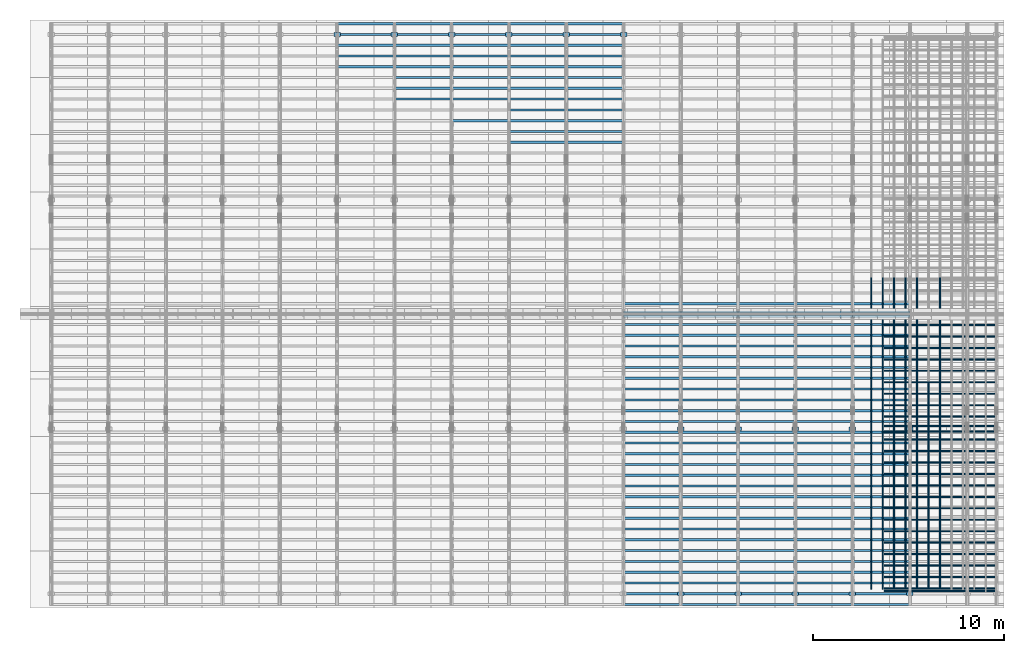
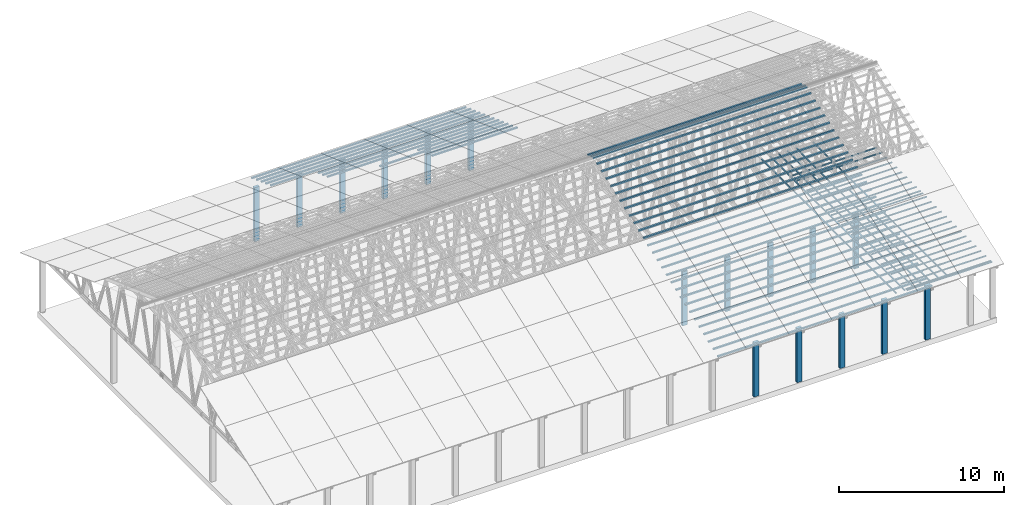
# One storey, part 3 of 189: 258 columns.
"""IFC2X3 building model written with IfcOpenShell, lengths in millimetres."""

from ifc_helpers import new_model, entity, si_unit, converted_unit, derived_unit, direction, frame, frame_2d, origin, origin_2d_with_axis, place, context, subcontext, project, spatial, rectangle, extrude, boolean, source, transform, mapped, material, type_object, type_shapes, element, save


model = new_model("IFC2X3")

# Units and contexts
model_context = context("Model", 3, precision=0.01, world=origin(), true_north=direction((6.12303176911189e-17, 1.0)))
body_context = subcontext(model_context, "Body", "Model", "MODEL_VIEW")
ifc_project = project(units=[si_unit("LENGTHUNIT", "METRE", prefix="MILLI"), si_unit("AREAUNIT", "SQUARE_METRE"), si_unit("VOLUMEUNIT", "CUBIC_METRE"), converted_unit("PLANEANGLEUNIT", "DEGREE", entity("IfcRatioMeasure", 0.0174532925199433), si_unit("PLANEANGLEUNIT", "RADIAN"), dimensions=[0, 0, 0, 0, 0, 0, 0]), si_unit("MASSUNIT", "GRAM", prefix="KILO"), derived_unit("MASSDENSITYUNIT", [(si_unit("MASSUNIT", "GRAM", prefix="KILO"), 1), (si_unit("LENGTHUNIT", "METRE"), -3)]), si_unit("TIMEUNIT", "SECOND"), si_unit("FREQUENCYUNIT", "HERTZ"), si_unit("THERMODYNAMICTEMPERATUREUNIT", "DEGREE_CELSIUS"), derived_unit("THERMALTRANSMITTANCEUNIT", [(si_unit("MASSUNIT", "GRAM", prefix="KILO"), 1), (si_unit("THERMODYNAMICTEMPERATUREUNIT", "KELVIN"), -1), (si_unit("TIMEUNIT", "SECOND"), -3)]), derived_unit("VOLUMETRICFLOWRATEUNIT", [(si_unit("LENGTHUNIT", "METRE"), 3), (si_unit("TIMEUNIT", "SECOND"), -1)]), si_unit("ELECTRICCURRENTUNIT", "AMPERE"), si_unit("ELECTRICVOLTAGEUNIT", "VOLT"), si_unit("POWERUNIT", "WATT"), si_unit("FORCEUNIT", "NEWTON"), si_unit("ILLUMINANCEUNIT", "LUX"), si_unit("LUMINOUSFLUXUNIT", "LUMEN"), si_unit("LUMINOUSINTENSITYUNIT", "CANDELA"), derived_unit("USERDEFINED", [(si_unit("MASSUNIT", "GRAM", prefix="KILO"), -1), (si_unit("LENGTHUNIT", "METRE"), -2), (si_unit("TIMEUNIT", "SECOND"), 3), (si_unit("LUMINOUSFLUXUNIT", "LUMEN"), 1)]), derived_unit("LINEARVELOCITYUNIT", [(si_unit("LENGTHUNIT", "METRE"), 1), (si_unit("TIMEUNIT", "SECOND"), -1)]), si_unit("PRESSUREUNIT", "PASCAL"), derived_unit("USERDEFINED", [(si_unit("LENGTHUNIT", "METRE"), -2), (si_unit("MASSUNIT", "GRAM", prefix="KILO"), 1), (si_unit("TIMEUNIT", "SECOND"), -2)])], contexts=[model_context])

# Site, building, storey
site_placement = place(None, origin())
site = spatial("IfcSite", under=ifc_project, at=site_placement, CompositionType="ELEMENT")
building_placement = place(site_placement, origin())
building = spatial("IfcBuilding", under=site, at=building_placement, CompositionType="ELEMENT")
storey_placement = place(building_placement, origin())
storey = spatial("IfcBuildingStorey", under=building, at=storey_placement, Name="Default", CompositionType="ELEMENT", Elevation=0.0)

# Columns
ifc_material_1 = material(Name="2")
column_type_1 = type_object("IfcColumnType", Name="100x70", PredefinedType="COLUMN")
shared_shape_1 = source(origin(), body_context, "Body", "CSG", [
    boolean("DIFFERENCE", extrude(rectangle(XDim=2998.26294985256, YDim=117.910672112436, at=frame_2d((0.0, -7.105427357601e-15), x_axis=(1.0, 0.0))), frame((1499.13147492628, 146.833369190677, -28.6286403914047)), (0.0, 0.0, 1.0), 99.9804977897746), extrude(rectangle(XDim=70.0000000018648, YDim=100.00000000027, at=frame_2d((3.5527136788005e-15, 3.5527136788005e-15), x_axis=(0.0, 1.0))), frame((2998.26294985256, 146.833369190677, 21.3616085034827), z_axis=(1.0, 0.0, 0.0), x_axis=(0.0, 0.939692620784201, -0.34202014333036)), (0.0, 0.0, -1.0), 2998.26294985256)),
])
type_shapes(column_type_1, [shared_shape_1])
for number, where, name in (
    (1, (42230.0, 15149.3712807029, 5585.64342365955), "H_28_35_gradi:100x70"),
    (2, (42230.0, 14712.1220107287, 5744.78914288479), "H_28_35_gradi:100x70"),
    (3, (39231.7370501475, 15149.3712807029, 5585.64342365955), "H_28_35_gradi:100x70"),
    (4, (39231.7370501475, 14712.1220107287, 5744.78914288479), "H_28_35_gradi:100x70"),
    (5, (36233.4741002949, 15149.3712807029, 5585.64342365955), "H_28_35_gradi:100x70"),
    (6, (36233.4741002949, 14712.1220107287, 5744.78914288479), "H_28_35_gradi:100x70"),
    (7, (33235.2111504423, 15149.3712807029, 5585.64342365955), "H_28_35_gradi:100x70"),
    (8, (33235.2111504423, 14712.1220107287, 5744.78914288479), "H_28_35_gradi:100x70"),
    (9, (30236.9482005898, 15149.3712807029, 5585.64342365955), "H_28_35_gradi:100x70"),
    (10, (30236.9482005898, 14712.1220107287, 5744.78914288479), "H_28_35_gradi:100x70"),
    (11, (27231.7370501475, 29808.5761649638, 250.129187781087), "H_28_35_gradi:100x70"),
    (12, (27231.7370501475, 29244.7605924922, 455.341273776488), "H_28_35_gradi:100x70"),
    (13, (27231.7370501475, 28680.94502002, 660.553359769929), "H_28_35_gradi:100x70"),
    (14, (27231.7370501475, 28117.1294475484, 865.765445765329), "H_28_35_gradi:100x70"),
    (15, (27231.7370501475, 27553.3138750769, 1070.97753176073), "H_28_35_gradi:100x70"),
    (16, (27231.7370501475, 26989.4983026054, 1276.18961775613), "H_28_35_gradi:100x70"),
    (17, (27231.7370501475, 26425.6827301338, 1481.40170375153), "H_28_35_gradi:100x70"),
    (18, (27231.7370501475, 25861.8671576623, 1686.61378974693), "H_28_35_gradi:100x70"),
    (19, (27231.7370501475, 25298.0515851907, 1891.82587574233), "H_28_35_gradi:100x70"),
    (20, (27231.7370501475, 24734.2360127192, 2097.03796173773), "H_28_35_gradi:100x70"),
    (21, (27231.7370501475, 24170.4204402476, 2302.25004773314), "H_28_35_gradi:100x70"),
    (22, (27231.7370501475, 23606.6048677761, 2507.46213372854), "H_28_35_gradi:100x70"),
    (23, (24233.4741002949, 29808.5761649638, 250.129187781087), "H_28_35_gradi:100x70"),
    (24, (24233.4741002949, 29244.7605924923, 455.341273776488), "H_28_35_gradi:100x70"),
    (25, (24233.4741002949, 28680.94502002, 660.553359769929), "H_28_35_gradi:100x70"),
    (26, (24233.4741002949, 28117.1294475485, 865.765445765329), "H_28_35_gradi:100x70"),
    (27, (24233.4741002949, 27553.3138750769, 1070.97753176073), "H_28_35_gradi:100x70"),
    (28, (24233.4741002949, 26989.4983026054, 1276.18961775613), "H_28_35_gradi:100x70"),
    (29, (24233.4741002949, 26425.6827301338, 1481.40170375153), "H_28_35_gradi:100x70"),
    (30, (24233.4741002949, 25861.8671576623, 1686.61378974693), "H_28_35_gradi:100x70"),
    (31, (24233.4741002949, 25298.0515851907, 1891.82587574233), "H_28_35_gradi:100x70"),
    (32, (24233.4741002949, 24734.2360127192, 2097.03796173773), "H_28_35_gradi:100x70"),
    (33, (24233.4741002949, 24170.4204402477, 2302.25004773314), "H_28_35_gradi:100x70"),
    (34, (24233.4741002949, 23606.6048677761, 2507.46213372854), "H_28_35_gradi:100x70"),
    (35, (21235.2111504423, 29808.5761649638, 250.129187781087), "H_28_35_gradi:100x70"),
    (36, (21235.2111504423, 29244.7605924923, 455.341273776488), "H_28_35_gradi:100x70"),
    (37, (21235.2111504423, 28680.94502002, 660.553359769929), "H_28_35_gradi:100x70"),
    (38, (21235.2111504423, 28117.1294475485, 865.765445765329), "H_28_35_gradi:100x70"),
    (39, (21235.2111504423, 27553.3138750769, 1070.97753176073), "H_28_35_gradi:100x70"),
    (40, (21235.2111504423, 26989.4983026054, 1276.18961775613), "H_28_35_gradi:100x70"),
    (41, (21235.2111504423, 26425.6827301338, 1481.40170375153), "H_28_35_gradi:100x70"),
    (42, (21235.2111504423, 25861.8671576623, 1686.61378974693), "H_28_35_gradi:100x70"),
    (43, (21235.2111504423, 24734.2360127192, 2097.03796173773), "H_28_35_gradi:100x70"),
    (44, (18231.7370501475, 29808.5761649638, 250.129187781087), "H_28_35_gradi:100x70"),
    (45, (18231.7370501475, 29244.7605924923, 455.341273776488), "H_28_35_gradi:100x70"),
    (46, (18231.7370501475, 28680.94502002, 660.553359769929), "H_28_35_gradi:100x70"),
    (47, (18231.7370501475, 28117.1294475485, 865.765445765329), "H_28_35_gradi:100x70"),
    (48, (18231.7370501475, 27553.3138750769, 1070.97753176073), "H_28_35_gradi:100x70"),
    (49, (18231.7370501475, 26989.4983026054, 1276.18961775613), "H_28_35_gradi:100x70"),
    (50, (18231.7370501475, 26425.6827301338, 1481.40170375153), "H_28_35_gradi:100x70"),
    (51, (18231.7370501475, 25861.8671576623, 1686.61378974693), "H_28_35_gradi:100x70"),
    (52, (15233.4741002949, 29808.5761649638, 250.129187781087), "H_28_35_gradi:100x70"),
    (53, (15233.4741002949, 29244.7605924923, 455.341273776488), "H_28_35_gradi:100x70"),
    (54, (15233.4741002949, 28680.94502002, 660.553359769929), "H_28_35_gradi:100x70"),
    (55, (15233.4741002949, 28117.1294475485, 865.765445765329), "H_28_35_gradi:100x70"),
    (56, (15233.4741002949, 27553.3138750769, 1070.97753176073), "H_28_35_gradi:100x70"),
):
    element("IfcColumn", number, at=place(storey_placement, frame(where)), inside=storey, type_object=column_type_1, material=ifc_material_1, Name=name, ObjectType="H_28_35_gradi:100x70", context=body_context, shape_type="MappedRepresentation", body=[
        mapped(shared_shape_1, transform((0.0, 0.0, 0.0), scale=1.0)),
    ])
column_type_2 = type_object("IfcColumnType", Name="100x70", PredefinedType="COLUMN")
shared_shape_2 = source(origin(), body_context, "Body", "CSG", [
    boolean("DIFFERENCE", extrude(rectangle(XDim=2998.26294985257, YDim=117.910672112436, at=frame_2d((0.0, 7.105427357601e-15), x_axis=(1.0, 0.0))), frame((1499.13147492629, -146.833369190677, -28.6286403914047)), (0.0, 0.0, 1.0), 99.9804977897746), extrude(rectangle(XDim=70.0000000018648, YDim=100.00000000027, at=frame_2d((3.5527136788005e-15, 3.5527136788005e-15), x_axis=(0.0, 1.0))), frame((0.0, -146.833369190677, 21.3616085034827), z_axis=(-1.0, 0.0, 0.0), x_axis=(0.0, -0.939692620784201, -0.34202014333036)), (0.0, 0.0, -1.0), 2998.26294985257)),
])
type_shapes(column_type_2, [shared_shape_2])
for number, where, name in (
    (57, (42230.0, 255.239495233961, 455.341273776488), "H_28_35_gradi:100x70"),
    (58, (42230.0, 819.05506770622, 660.553359769929), "H_28_35_gradi:100x70"),
    (59, (42230.0, 1382.87064017776, 865.765445765329), "H_28_35_gradi:100x70"),
    (60, (42230.0, 1946.68621264931, 1070.97753176073), "H_28_35_gradi:100x70"),
    (61, (42230.0, 2510.50178512085, 1276.18961775613), "H_28_35_gradi:100x70"),
    (62, (42230.0, 3074.31735759239, 1481.40170375153), "H_28_35_gradi:100x70"),
    (63, (42230.0, 3638.13293006394, 1686.61378974693), "H_28_35_gradi:100x70"),
    (64, (42230.0, 4201.94850253548, 1891.82587574233), "H_28_35_gradi:100x70"),
    (65, (42230.0, 4765.76407500702, 2097.03796173773), "H_28_35_gradi:100x70"),
    (66, (42230.0, 5329.57964747857, 2302.25004773314), "H_28_35_gradi:100x70"),
    (67, (42230.0, 5893.39521995011, 2507.46213372854), "H_28_35_gradi:100x70"),
    (68, (42230.0, 6457.21079242165, 2712.67421972394), "H_28_35_gradi:100x70"),
    (69, (42230.0, 7021.0263648932, 2917.88630571934), "H_28_35_gradi:100x70"),
    (70, (42230.0, 7584.84193736474, 3123.09839171474), "H_28_35_gradi:100x70"),
    (71, (42230.0, 8148.65750983629, 3328.31047771014), "H_28_35_gradi:100x70"),
    (72, (42230.0, 8712.47308230783, 3533.52256370554), "H_28_35_gradi:100x70"),
    (73, (42230.0, 9276.28865477938, 3738.73464970094), "H_28_35_gradi:100x70"),
    (74, (42230.0, 9840.10422725092, 3943.94673569634), "H_28_35_gradi:100x70"),
    (75, (42230.0, 10403.9197997225, 4149.15882169174), "H_28_35_gradi:100x70"),
    (76, (42230.0, 10967.735372194, 4354.37090768715), "H_28_35_gradi:100x70"),
    (77, (42230.0, 11531.5509446656, 4559.58299368255), "H_28_35_gradi:100x70"),
    (78, (42230.0, 12095.3665171371, 4764.79507967795), "H_28_35_gradi:100x70"),
    (79, (42230.0, 12659.1820896086, 4970.00716567335), "H_28_35_gradi:100x70"),
    (80, (42230.0, 13222.9976620802, 5175.21925166875), "H_28_35_gradi:100x70"),
    (81, (42230.0, 13786.8132345517, 5380.43133766415), "H_28_35_gradi:100x70"),
    (82, (42230.0, 14350.6288070233, 5585.64342365955), "H_28_35_gradi:100x70"),
    (83, (42230.0, 14787.8780769975, 5744.78914288479), "H_28_35_gradi:100x70"),
    (84, (42230.0, -308.576077237584, 250.129187781088), "H_28_35_gradi:100x70"),
    (85, (39231.7370501474, 255.23949523397, 455.341273776488), "H_28_35_gradi:100x70"),
    (86, (39231.7370501474, 819.05506770623, 660.553359769929), "H_28_35_gradi:100x70"),
    (87, (39231.7370501474, 1382.87064017777, 865.765445765329), "H_28_35_gradi:100x70"),
    (88, (39231.7370501474, 1946.68621264932, 1070.97753176073), "H_28_35_gradi:100x70"),
    (89, (39231.7370501474, 2510.50178512086, 1276.18961775613), "H_28_35_gradi:100x70"),
    (90, (39231.7370501474, 3074.3173575924, 1481.40170375153), "H_28_35_gradi:100x70"),
    (91, (39231.7370501474, 3638.13293006395, 1686.61378974693), "H_28_35_gradi:100x70"),
    (92, (39231.7370501474, 4201.94850253549, 1891.82587574233), "H_28_35_gradi:100x70"),
    (93, (39231.7370501474, 4765.76407500703, 2097.03796173773), "H_28_35_gradi:100x70"),
    (94, (39231.7370501474, 5329.57964747858, 2302.25004773314), "H_28_35_gradi:100x70"),
    (95, (39231.7370501474, 5893.39521995012, 2507.46213372854), "H_28_35_gradi:100x70"),
    (96, (39231.7370501475, 6457.21079242166, 2712.67421972394), "H_28_35_gradi:100x70"),
    (97, (39231.7370501475, 7021.02636489321, 2917.88630571934), "H_28_35_gradi:100x70"),
    (98, (39231.7370501475, 7584.84193736475, 3123.09839171474), "H_28_35_gradi:100x70"),
    (99, (39231.7370501475, 8148.6575098363, 3328.31047771014), "H_28_35_gradi:100x70"),
    (100, (39231.7370501475, 8712.47308230784, 3533.52256370554), "H_28_35_gradi:100x70"),
    (101, (39231.7370501475, 9276.28865477939, 3738.73464970094), "H_28_35_gradi:100x70"),
    (102, (39231.7370501475, 9840.10422725093, 3943.94673569634), "H_28_35_gradi:100x70"),
    (103, (39231.7370501475, 10403.9197997225, 4149.15882169174), "H_28_35_gradi:100x70"),
    (104, (39231.7370501475, 10967.735372194, 4354.37090768715), "H_28_35_gradi:100x70"),
    (105, (39231.7370501475, 11531.5509446656, 4559.58299368255), "H_28_35_gradi:100x70"),
    (106, (39231.7370501475, 12095.3665171371, 4764.79507967795), "H_28_35_gradi:100x70"),
    (107, (39231.7370501475, 12659.1820896087, 4970.00716567335), "H_28_35_gradi:100x70"),
    (108, (39231.7370501475, 13222.9976620802, 5175.21925166875), "H_28_35_gradi:100x70"),
    (109, (39231.7370501475, 13786.8132345517, 5380.43133766415), "H_28_35_gradi:100x70"),
    (110, (39231.7370501475, 14350.6288070233, 5585.64342365955), "H_28_35_gradi:100x70"),
    (111, (39231.7370501475, 14787.8780769975, 5744.78914288479), "H_28_35_gradi:100x70"),
    (112, (39231.7370501474, -308.576077237574, 250.129187781088), "H_28_35_gradi:100x70"),
    (113, (36233.4741002948, 255.23949523398, 455.341273776488), "H_28_35_gradi:100x70"),
    (114, (36233.4741002948, 819.05506770624, 660.553359769929), "H_28_35_gradi:100x70"),
    (115, (36233.4741002948, 1382.87064017778, 865.765445765329), "H_28_35_gradi:100x70"),
    (116, (36233.4741002948, 1946.68621264932, 1070.97753176073), "H_28_35_gradi:100x70"),
    (117, (36233.4741002949, 2510.50178512087, 1276.18961775613), "H_28_35_gradi:100x70"),
    (118, (36233.4741002949, 3074.31735759241, 1481.40170375153), "H_28_35_gradi:100x70"),
    (119, (36233.4741002949, 3638.13293006396, 1686.61378974693), "H_28_35_gradi:100x70"),
    (120, (36233.4741002949, 4201.9485025355, 1891.82587574233), "H_28_35_gradi:100x70"),
    (121, (36233.4741002949, 4765.76407500704, 2097.03796173773), "H_28_35_gradi:100x70"),
    (122, (36233.4741002949, 5329.57964747859, 2302.25004773314), "H_28_35_gradi:100x70"),
    (123, (36233.4741002949, 5893.39521995013, 2507.46213372854), "H_28_35_gradi:100x70"),
    (124, (36233.4741002949, 6457.21079242167, 2712.67421972394), "H_28_35_gradi:100x70"),
    (125, (36233.4741002949, 7021.02636489322, 2917.88630571934), "H_28_35_gradi:100x70"),
    (126, (36233.4741002949, 7584.84193736476, 3123.09839171474), "H_28_35_gradi:100x70"),
    (127, (36233.4741002949, 8148.65750983631, 3328.31047771014), "H_28_35_gradi:100x70"),
    (128, (36233.4741002949, 8712.47308230785, 3533.52256370554), "H_28_35_gradi:100x70"),
    (129, (36233.4741002949, 9276.2886547794, 3738.73464970094), "H_28_35_gradi:100x70"),
    (130, (36233.4741002949, 9840.10422725093, 3943.94673569634), "H_28_35_gradi:100x70"),
    (131, (36233.4741002949, 10403.9197997225, 4149.15882169174), "H_28_35_gradi:100x70"),
    (132, (36233.4741002949, 10967.735372194, 4354.37090768715), "H_28_35_gradi:100x70"),
    (133, (36233.4741002949, 11531.5509446656, 4559.58299368255), "H_28_35_gradi:100x70"),
    (134, (36233.4741002949, 12095.3665171371, 4764.79507967795), "H_28_35_gradi:100x70"),
    (135, (36233.4741002949, 12659.1820896087, 4970.00716567335), "H_28_35_gradi:100x70"),
    (136, (36233.4741002949, 13222.9976620802, 5175.21925166875), "H_28_35_gradi:100x70"),
    (137, (36233.4741002949, 13786.8132345518, 5380.43133766415), "H_28_35_gradi:100x70"),
    (138, (36233.4741002949, 14350.6288070233, 5585.64342365955), "H_28_35_gradi:100x70"),
    (139, (36233.4741002949, 14787.8780769975, 5744.78914288479), "H_28_35_gradi:100x70"),
    (140, (36233.4741002948, -308.576077237565, 250.129187781088), "H_28_35_gradi:100x70"),
    (141, (33235.2111504423, 255.23949523399, 455.341273776488), "H_28_35_gradi:100x70"),
    (142, (33235.2111504423, 819.055067706249, 660.553359769929), "H_28_35_gradi:100x70"),
    (143, (33235.2111504423, 1382.87064017779, 865.765445765329), "H_28_35_gradi:100x70"),
    (144, (33235.2111504423, 1946.68621264933, 1070.97753176073), "H_28_35_gradi:100x70"),
    (145, (33235.2111504423, 2510.50178512088, 1276.18961775613), "H_28_35_gradi:100x70"),
    (146, (33235.2111504423, 3074.31735759242, 1481.40170375153), "H_28_35_gradi:100x70"),
    (147, (33235.2111504423, 3638.13293006396, 1686.61378974693), "H_28_35_gradi:100x70"),
    (148, (33235.2111504423, 4201.94850253551, 1891.82587574233), "H_28_35_gradi:100x70"),
    (149, (33235.2111504423, 4765.76407500705, 2097.03796173773), "H_28_35_gradi:100x70"),
    (150, (33235.2111504423, 5329.5796474786, 2302.25004773314), "H_28_35_gradi:100x70"),
    (151, (33235.2111504423, 5893.39521995014, 2507.46213372854), "H_28_35_gradi:100x70"),
    (152, (33235.2111504423, 6457.21079242168, 2712.67421972394), "H_28_35_gradi:100x70"),
    (153, (33235.2111504423, 7021.02636489323, 2917.88630571934), "H_28_35_gradi:100x70"),
    (154, (33235.2111504423, 7584.84193736477, 3123.09839171474), "H_28_35_gradi:100x70"),
    (155, (33235.2111504423, 8148.65750983631, 3328.31047771014), "H_28_35_gradi:100x70"),
    (156, (33235.2111504423, 8712.47308230786, 3533.52256370554), "H_28_35_gradi:100x70"),
    (157, (33235.2111504423, 9276.2886547794, 3738.73464970094), "H_28_35_gradi:100x70"),
    (158, (33235.2111504423, 9840.10422725094, 3943.94673569634), "H_28_35_gradi:100x70"),
    (159, (33235.2111504423, 10403.9197997225, 4149.15882169174), "H_28_35_gradi:100x70"),
    (160, (33235.2111504423, 10967.735372194, 4354.37090768715), "H_28_35_gradi:100x70"),
    (161, (33235.2111504423, 11531.5509446656, 4559.58299368255), "H_28_35_gradi:100x70"),
    (162, (33235.2111504423, 12095.3665171371, 4764.79507967795), "H_28_35_gradi:100x70"),
    (163, (33235.2111504423, 12659.1820896087, 4970.00716567335), "H_28_35_gradi:100x70"),
    (164, (33235.2111504423, 13222.9976620802, 5175.21925166875), "H_28_35_gradi:100x70"),
    (165, (33235.2111504423, 13786.8132345518, 5380.43133766415), "H_28_35_gradi:100x70"),
    (166, (33235.2111504423, 14350.6288070233, 5585.64342365955), "H_28_35_gradi:100x70"),
    (167, (33235.2111504423, 14787.8780769975, 5744.78914288479), "H_28_35_gradi:100x70"),
    (168, (33235.2111504423, -308.576077237555, 250.129187781088), "H_28_35_gradi:100x70"),
    (169, (30236.9482005897, 255.239495233999, 455.341273776488), "H_28_35_gradi:100x70"),
    (170, (30236.9482005897, 819.055067706259, 660.553359769929), "H_28_35_gradi:100x70"),
    (171, (30236.9482005897, 1382.8706401778, 865.765445765329), "H_28_35_gradi:100x70"),
    (172, (30236.9482005897, 1946.68621264934, 1070.97753176073), "H_28_35_gradi:100x70"),
    (173, (30236.9482005897, 2510.50178512089, 1276.18961775613), "H_28_35_gradi:100x70"),
    (174, (30236.9482005897, 3074.31735759243, 1481.40170375153), "H_28_35_gradi:100x70"),
    (175, (30236.9482005897, 3638.13293006397, 1686.61378974693), "H_28_35_gradi:100x70"),
    (176, (30236.9482005897, 4201.94850253552, 1891.82587574233), "H_28_35_gradi:100x70"),
    (177, (30236.9482005897, 4765.76407500706, 2097.03796173773), "H_28_35_gradi:100x70"),
    (178, (30236.9482005897, 5329.5796474786, 2302.25004773314), "H_28_35_gradi:100x70"),
    (179, (30236.9482005897, 5893.39521995015, 2507.46213372854), "H_28_35_gradi:100x70"),
    (180, (30236.9482005897, 6457.21079242169, 2712.67421972394), "H_28_35_gradi:100x70"),
    (181, (30236.9482005897, 7021.02636489324, 2917.88630571934), "H_28_35_gradi:100x70"),
    (182, (30236.9482005897, 7584.84193736478, 3123.09839171474), "H_28_35_gradi:100x70"),
    (183, (30236.9482005897, 8148.65750983632, 3328.31047771014), "H_28_35_gradi:100x70"),
    (184, (30236.9482005897, 8712.47308230787, 3533.52256370554), "H_28_35_gradi:100x70"),
    (185, (30236.9482005897, 9276.28865477942, 3738.73464970094), "H_28_35_gradi:100x70"),
    (186, (30236.9482005897, 9840.10422725095, 3943.94673569634), "H_28_35_gradi:100x70"),
    (187, (30236.9482005897, 10403.9197997225, 4149.15882169174), "H_28_35_gradi:100x70"),
    (188, (30236.9482005897, 10967.735372194, 4354.37090768715), "H_28_35_gradi:100x70"),
    (189, (30236.9482005897, 11531.5509446656, 4559.58299368255), "H_28_35_gradi:100x70"),
    (190, (30236.9482005897, 12095.3665171371, 4764.79507967795), "H_28_35_gradi:100x70"),
    (191, (30236.9482005897, 12659.1820896087, 4970.00716567335), "H_28_35_gradi:100x70"),
    (192, (30236.9482005897, 13222.9976620802, 5175.21925166875), "H_28_35_gradi:100x70"),
    (193, (30236.9482005897, 13786.8132345518, 5380.43133766415), "H_28_35_gradi:100x70"),
    (194, (30236.9482005898, 14350.6288070233, 5585.64342365955), "H_28_35_gradi:100x70"),
    (195, (30236.9482005898, 14787.8780769975, 5744.78914288479), "H_28_35_gradi:100x70"),
    (196, (30236.9482005897, -308.576077237545, 250.129187781088), "H_28_35_gradi:100x70"),
):
    element("IfcColumn", number, at=place(storey_placement, frame(where)), inside=storey, type_object=column_type_2, material=ifc_material_1, Name=name, ObjectType="H_28_35_gradi:100x70", context=body_context, shape_type="MappedRepresentation", body=[
        mapped(shared_shape_2, transform((0.0, 0.0, 0.0), scale=1.0)),
    ])
column_type_3 = type_object("IfcColumnType", Name="45x70", PredefinedType="COLUMN")
shared_shape_3 = source(origin(), body_context, "Body", "SweptSolid", [
    extrude(rectangle(XDim=70.0000000000007, YDim=5950.0, at=frame_2d((1.66977542903624e-13, 0.0), x_axis=(1.0, 0.0))), frame((2975.0, 237.823014276398, 0.0), z_axis=(0.0, 0.0, 1.0), x_axis=(0.0, -1.0, 0.0)), (0.0, 0.0, 1.0), 44.9999999999788),
])
type_shapes(column_type_3, [shared_shape_3])
for number, where, z_axis, x_axis, name in (
    (197, (49837.7477027694, 617.823014276399, -45.0), (0.0, 0.0, 1.0), (-1.0, 0.0, 0.0), "H:45x70"),
    (198, (49837.7477027694, 1217.8230142764, -45.0), (0.0, 0.0, 1.0), (-1.0, 0.0, 0.0), "H:45x70"),
    (199, (49837.7477027694, 1817.8230142764, -45.0), (0.0, 0.0, 1.0), (-1.0, 0.0, 0.0), "H:45x70"),
    (200, (49837.7477027694, 2417.8230142764, -45.0), (0.0, 0.0, 1.0), (-1.0, 0.0, 0.0), "H:45x70"),
    (201, (49837.7477027694, 3017.8230142764, -45.0), (0.0, 0.0, 1.0), (-1.0, 0.0, 0.0), "H:45x70"),
    (202, (49837.7477027694, 3617.8230142764, -45.0), (0.0, 0.0, 1.0), (-1.0, 0.0, 0.0), "H:45x70"),
    (203, (49837.7477027694, 4217.8230142764, -45.0), (0.0, 0.0, 1.0), (-1.0, 0.0, 0.0), "H:45x70"),
    (204, (49837.7477027694, 4817.8230142764, -45.0), (0.0, 0.0, 1.0), (-1.0, 0.0, 0.0), "H:45x70"),
    (205, (49837.7477027694, 5417.8230142764, -45.0), (0.0, 0.0, 1.0), (-1.0, 0.0, 0.0), "H:45x70"),
    (206, (49837.7477027694, 6017.8230142764, -45.0), (0.0, 0.0, 1.0), (-1.0, 0.0, 0.0), "H:45x70"),
    (207, (49837.7477027694, 6617.8230142764, -45.0), (0.0, 0.0, 1.0), (-1.0, 0.0, 0.0), "H:45x70"),
    (208, (49837.7477027694, 7217.8230142764, -45.0), (0.0, 0.0, 1.0), (-1.0, 0.0, 0.0), "H:45x70"),
    (209, (49837.7477027694, 7817.8230142764, -45.0), (0.0, 0.0, 1.0), (-1.0, 0.0, 0.0), "H:45x70"),
    (210, (49837.7477027694, 8417.8230142764, -45.0), (0.0, 0.0, 1.0), (-1.0, 0.0, 0.0), "H:45x70"),
    (211, (49837.7477027694, 9617.8230142764, -45.0), (0.0, 0.0, 1.0), (-1.0, 0.0, 0.0), "H:45x70"),
    (212, (49837.7477027694, 10217.8230142764, -45.0), (0.0, 0.0, 1.0), (-1.0, 0.0, 0.0), "H:45x70"),
    (213, (49837.7477027694, 10817.8230142764, -45.0), (0.0, 0.0, 1.0), (-1.0, 0.0, 0.0), "H:45x70"),
    (214, (49837.7477027694, 11417.8230142764, -45.0), (0.0, 0.0, 1.0), (-1.0, 0.0, 0.0), "H:45x70"),
    (215, (49837.7477027694, 12017.8230142764, -45.0), (0.0, 0.0, 1.0), (-1.0, 0.0, 0.0), "H:45x70"),
    (216, (49837.7477027694, 12617.8230142764, -45.0), (0.0, 0.0, 1.0), (-1.0, 0.0, 0.0), "H:45x70"),
    (217, (49837.7477027694, 13217.8230142764, -45.0), (0.0, 0.0, 1.0), (-1.0, 0.0, 0.0), "H:45x70"),
    (218, (49837.7477027694, 13817.8230142764, -45.0), (0.0, 0.0, 1.0), (-1.0, 0.0, 0.0), "H:45x70"),
    (219, (49837.7477027694, 14417.8230142764, -45.0), (0.0, 0.0, 1.0), (-1.0, 0.0, 0.0), "H:45x70"),
    (220, (49837.7477027694, 477.823014276399, -45.0), (0.0, 0.0, 1.0), (-1.0, 0.0, 0.0), "H:45x70"),
    (221, (49837.7477027694, 9127.82301427626, -45.0), (0.0, 0.0, 1.0), (-1.0, 0.0, 0.0), "H:45x70"),
    (222, (49837.7477027694, 8848.21200534614, -45.0), (0.0, 0.0, 1.0), (-1.0, 0.0, 0.0), "H:45x70"),
):
    element("IfcColumn", number, at=place(storey_placement, frame(where, z_axis=z_axis, x_axis=x_axis)), inside=storey, type_object=column_type_3, material=ifc_material_1, Name=name, ObjectType="H:45x70", context=body_context, shape_type="MappedRepresentation", body=[
        mapped(shared_shape_3, transform((0.0, 0.0, 0.0), scale=1.0)),
    ])
column_type_4 = type_object("IfcColumnType", Name="45x70", PredefinedType="COLUMN")
shared_shape_4 = source(origin(), body_context, "Body", "SweptSolid", [
    extrude(rectangle(XDim=70.0000000000007, YDim=5434.29684744924, at=frame_2d((1.66977542903624e-13, 0.0), x_axis=(1.0, 0.0))), frame((2717.14842372462, 237.823014276398, 0.0), z_axis=(0.0, 0.0, 1.0), x_axis=(0.0, -1.0, 0.0)), (0.0, 0.0, 1.0), 44.9999999999788),
])
type_shapes(column_type_4, [shared_shape_4])
for number, where, z_axis, x_axis, name in (
    (223, (47040.5707170458, 345.0, -90.0), (0.0, 0.0, 1.0), (0.0, 1.0, 0.0), "H:45x70"),
    (224, (47040.5707170458, 5779.29684744924, -90.0), (0.0, 0.0, 1.0), (0.0, 1.0, 0.0), "H:45x70"),
    (225, (47040.5707170458, 11213.5936948985, -90.0), (0.0, 0.0, 1.0), (0.0, 1.0, 0.0), "H:45x70"),
    (226, (46440.5707170458, 345.0, -90.0), (0.0, 0.0, 1.0), (0.0, 1.0, 0.0), "H:45x70"),
    (227, (46440.5707170458, 5779.29684744925, -90.0), (0.0, 0.0, 1.0), (0.0, 1.0, 0.0), "H:45x70"),
    (228, (45840.5707170458, 345.0, -90.0), (0.0, 0.0, 1.0), (0.0, 1.0, 0.0), "H:45x70"),
    (229, (45840.5707170458, 5779.29684744925, -90.0), (0.0, 0.0, 1.0), (0.0, 1.0, 0.0), "H:45x70"),
    (230, (45840.5707170458, 11213.5936948985, -90.0), (0.0, 0.0, 1.0), (0.0, 1.0, 0.0), "H:45x70"),
    (231, (45240.5707170458, 345.0, -90.0), (0.0, 0.0, 1.0), (0.0, 1.0, 0.0), "H:45x70"),
    (232, (45240.5707170458, 5779.29684744925, -90.0), (0.0, 0.0, 1.0), (0.0, 1.0, 0.0), "H:45x70"),
    (233, (45240.5707170458, 11213.5936948985, -90.0), (0.0, 0.0, 1.0), (0.0, 1.0, 0.0), "H:45x70"),
    (234, (44640.5707170458, 345.0, -90.0), (0.0, 0.0, 1.0), (0.0, 1.0, 0.0), "H:45x70"),
    (235, (44640.5707170458, 5779.29684744925, -90.0), (0.0, 0.0, 1.0), (0.0, 1.0, 0.0), "H:45x70"),
    (236, (44640.5707170458, 11213.5936948985, -90.0), (0.0, 0.0, 1.0), (0.0, 1.0, 0.0), "H:45x70"),
    (237, (44040.5707170458, 345.0, -90.0), (0.0, 0.0, 1.0), (0.0, 1.0, 0.0), "H:45x70"),
    (238, (44040.5707170458, 5779.29684744926, -90.0), (0.0, 0.0, 1.0), (0.0, 1.0, 0.0), "H:45x70"),
    (239, (44040.5707170458, 11213.5936948985, -90.0), (0.0, 0.0, 1.0), (0.0, 1.0, 0.0), "H:45x70"),
    (240, (43440.5707170458, 345.0, -90.0), (0.0, 0.0, 1.0), (0.0, 1.0, 0.0), "H:45x70"),
    (241, (43440.5707170458, 5779.29684744926, -90.0), (0.0, 0.0, 1.0), (0.0, 1.0, 0.0), "H:45x70"),
    (242, (43440.5707170458, 11213.5936948985, -90.0), (0.0, 0.0, 1.0), (0.0, 1.0, 0.0), "H:45x70"),
):
    element("IfcColumn", number, at=place(storey_placement, frame(where, z_axis=z_axis, x_axis=x_axis)), inside=storey, type_object=column_type_4, material=ifc_material_1, Name=name, ObjectType="H:45x70", context=body_context, shape_type="MappedRepresentation", body=[
        mapped(shared_shape_4, transform((0.0, 0.0, 0.0), scale=1.0)),
    ])
ifc_material_2 = material()
column_type_5 = type_object("IfcColumnType", Name="200x200", PredefinedType="COLUMN")
shared_shape_5 = source(origin(), body_context, "Body", "SweptSolid", [
    extrude(rectangle(XDim=339.999999999998, YDim=200.000000000004, at=origin_2d_with_axis()), frame((100.0, 280.0, -4000.0), z_axis=(0.0, 0.0, 1.0), x_axis=(0.0, -1.0, 0.0)), (0.0, 0.0, 1.0), 4000.0),
])
type_shapes(column_type_5, [shared_shape_5])
for number, where, z_axis, x_axis, name in (
    (243, (45510.0, 0.0, 0.0), (0.0, 0.0, 1.0), (0.0, 1.0, 0.0), "V:200x200"),
    (244, (42490.0, 0.0, 0.0), (0.0, 0.0, 1.0), (0.0, 1.0, 0.0), "V:200x200"),
    (245, (39510.0, 0.0, 0.0), (0.0, 0.0, 1.0), (0.0, 1.0, 0.0), "V:200x200"),
    (246, (36510.0, 0.0, 0.0), (0.0, 0.0, 1.0), (0.0, 1.0, 0.0), "V:200x200"),
    (247, (33510.0, 0.0, 0.0), (0.0, 0.0, 1.0), (0.0, 1.0, 0.0), "V:200x200"),
    (248, (45510.0, 8650.0, 0.0), (0.0, 0.0, 1.0), (0.0, 1.0, 0.0), "V:200x200"),
    (249, (42490.0, 8650.0, 0.0), (0.0, 0.0, 1.0), (0.0, 1.0, 0.0), "V:200x200"),
    (250, (39510.0, 8650.0, 0.0), (0.0, 0.0, 1.0), (0.0, 1.0, 0.0), "V:200x200"),
    (251, (36510.0, 8650.0, 0.0), (0.0, 0.0, 1.0), (0.0, 1.0, 0.0), "V:200x200"),
    (252, (33510.0, 8650.0, 0.0), (0.0, 0.0, 1.0), (0.0, 1.0, 0.0), "V:200x200"),
    (253, (30510.0, 29300.0, 0.0), (0.0, 0.0, 1.0), (0.0, 1.0, 0.0), "V:200x200"),
    (254, (27510.0, 29300.0, 0.0), (0.0, 0.0, 1.0), (0.0, 1.0, 0.0), "V:200x200"),
    (255, (24510.0, 29300.0, 0.0), (0.0, 0.0, 1.0), (0.0, 1.0, 0.0), "V:200x200"),
    (256, (21510.0, 29300.0, 0.0), (0.0, 0.0, 1.0), (0.0, 1.0, 0.0), "V:200x200"),
    (257, (18510.0, 29300.0, 0.0), (0.0, 0.0, 1.0), (0.0, 1.0, 0.0), "V:200x200"),
    (258, (15510.0, 29300.0, 0.0), (0.0, 0.0, 1.0), (0.0, 1.0, 0.0), "V:200x200"),
):
    element("IfcColumn", number, at=place(storey_placement, frame(where, z_axis=z_axis, x_axis=x_axis)), inside=storey, type_object=column_type_5, material=ifc_material_2, Name=name, ObjectType="V:200x200", context=body_context, shape_type="MappedRepresentation", body=[
        mapped(shared_shape_5, transform((0.0, 0.0, 0.0), scale=1.0)),
    ])

save(model, "model.ifc")
